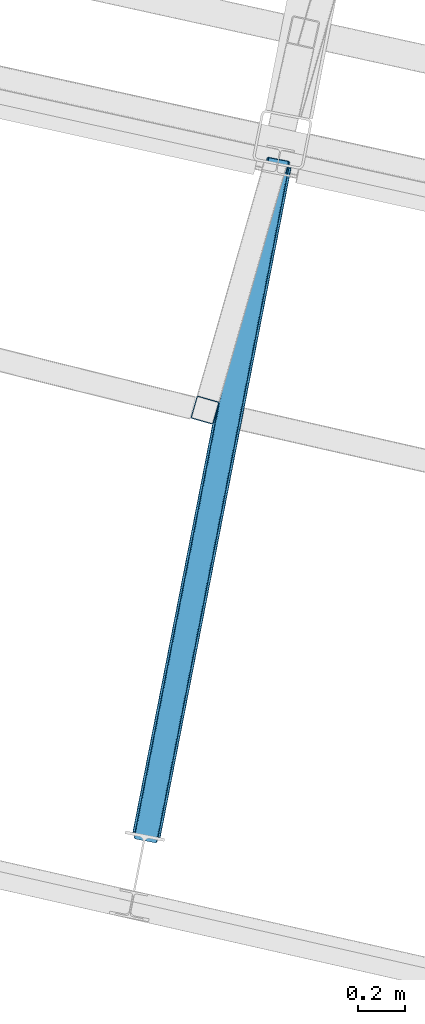
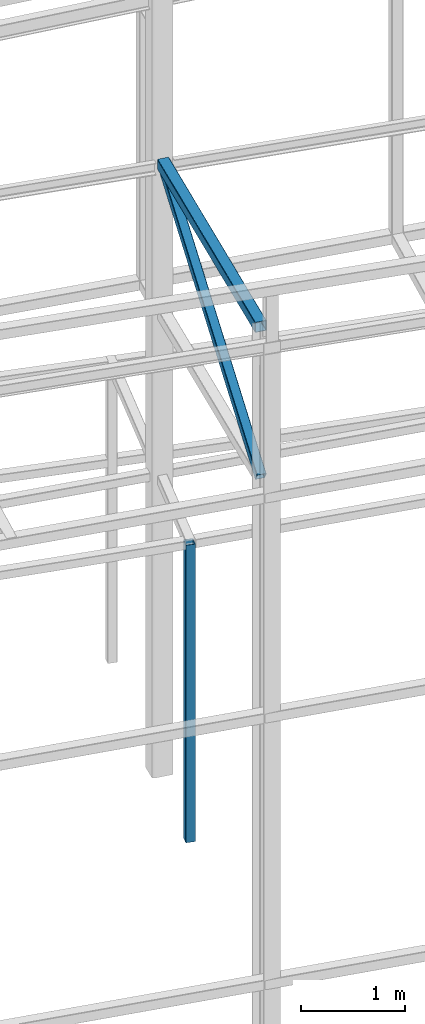
# One storey, part 15 of 215: 2 beams, 1 member, 3 elements without a shape of their own.
"""IFC2X3 building model written with IfcOpenShell, lengths in millimetres."""

import ifcopenshell
import ifcopenshell.guid

model = None  # the IFC model being written
_history = None  # IfcOwnerHistory: only IFC2X3 demands one
_inside = {}  # id of a spatial element -> (the spatial element, [elements in it])
_under = {}  # id of a project, library or spatial element -> (it, [spatial elements below it])
_declared = {}  # id of a project -> (the project, [libraries it declares])
_typed = {}  # id of a type object -> (the type object, [elements of that type])
_made_of = {}  # id of a material, layer set ... -> (it, [elements and type objects made of it])


def new_model(schema):
    """Start an empty IFC model of exactly this schema.

    Asked for "IFC4X3", IfcOpenShell would pick the latest addendum, in which some entities
    have other attributes; the version numbers below select the first issue.
    IFC2X3 requires an IfcOwnerHistory on every rooted entity: one is made here for all.
    """
    global model, _history
    if schema == "IFC4X3":
        model = ifcopenshell.file(schema_version=(4, 3, 0, 0))
    else:
        model = ifcopenshell.file(schema=schema)
    _inside.clear()
    _under.clear()
    _declared.clear()
    _typed.clear()
    _made_of.clear()
    _history = None
    if model.schema == "IFC2X3":
        org = make("IfcOrganization", Name="unknown")
        user = make(
            "IfcPersonAndOrganization",
            ThePerson=make("IfcPerson", FamilyName="unknown"),
            TheOrganization=org,
        )
        app = make(
            "IfcApplication",
            ApplicationDeveloper=org,
            Version="unknown",
            ApplicationFullName="unknown",
            ApplicationIdentifier="unknown",
        )
        _history = make(
            "IfcOwnerHistory",
            OwningUser=user,
            OwningApplication=app,
            ChangeAction="ADDED",
            CreationDate=0,
        )
    return model


def make(cls, **values):
    """One entity of the class cls with the attributes given. An attribute that is None is left unset."""
    return model.create_entity(
        cls, **{name: value for name, value in values.items() if value is not None}
    )


def rooted(cls, **values):
    """An entity with a GlobalId (a new one), such as an element, a storey or a relation."""
    return make(cls, GlobalId=ifcopenshell.guid.new(), OwnerHistory=_history, **values)


def si_unit(unit_type, name, prefix=None):
    """IfcSIUnit, for example si_unit("LENGTHUNIT", "METRE", prefix="MILLI")."""
    return make("IfcSIUnit", UnitType=unit_type, Prefix=prefix, Name=name)


def assignment(units):
    """IfcUnitAssignment: the units of a project."""
    return None if units is None else make("IfcUnitAssignment", Units=units)


def point(xyz):
    """IfcCartesianPoint."""
    return None if xyz is None else make("IfcCartesianPoint", Coordinates=xyz)


def direction(xyz):
    """IfcDirection."""
    return None if xyz is None else make("IfcDirection", DirectionRatios=xyz)


def frame(location, z_axis=None, x_axis=None):
    """IfcAxis2Placement3D, a coordinate frame: its origin and axes. An axis left out is left unset."""
    return make(
        "IfcAxis2Placement3D",
        Location=point(location),
        Axis=direction(z_axis),
        RefDirection=direction(x_axis),
    )


def frame_2d(location, x_axis=None):
    """IfcAxis2Placement2D, a coordinate frame in the plane: its origin and x axis."""
    return make(
        "IfcAxis2Placement2D", Location=point(location), RefDirection=direction(x_axis)
    )


def origin_with_axes():
    """The frame at (0, 0, 0) with the z axis (0, 0, 1) and the x axis (1, 0, 0) written out."""
    return frame((0.0, 0.0, 0.0), z_axis=(0.0, 0.0, 1.0), x_axis=(1.0, 0.0, 0.0))


def origin_2d_with_axis():
    """The frame at (0, 0) in the plane with the x axis (1, 0) written out."""
    return frame_2d((0.0, 0.0), x_axis=(1.0, 0.0))


def place(relative_to, where):
    """IfcLocalPlacement: puts the frame where relative to a parent placement (None: the world)."""
    return make(
        "IfcLocalPlacement", PlacementRelTo=relative_to, RelativePlacement=where
    )


def context(
    kind, dimensions, precision=None, world=None, true_north=None, identifier=None
):
    """IfcGeometricRepresentationContext, for example the 3D "Model" context."""
    return make(
        "IfcGeometricRepresentationContext",
        ContextIdentifier=identifier,
        ContextType=kind,
        CoordinateSpaceDimension=dimensions,
        Precision=precision,
        WorldCoordinateSystem=world,
        TrueNorth=true_north,
    )


def subcontext(parent, identifier, kind, view, scale=None):
    """IfcGeometricRepresentationSubContext, for example "Body" below "Model"."""
    return make(
        "IfcGeometricRepresentationSubContext",
        ContextIdentifier=identifier,
        ContextType=kind,
        ParentContext=parent,
        TargetScale=scale,
        TargetView=view,
    )


def project(units=None, contexts=None):
    """IfcProject with its units and contexts."""
    return rooted(
        "IfcProject",
        Name="project",
        RepresentationContexts=contexts,
        UnitsInContext=assignment(units),
    )


def spatial(cls, under=None, at=None, **own):
    """A site, building, storey or space (cls), placed at a placement, below another one or the project."""
    s = rooted(cls, ObjectPlacement=at, **own)
    if under is not None:
        _under.setdefault(under.id(), (under, []))[1].append(s)
    return s


def profile(cls, at=None, kind="AREA", **sizes):
    """A parametric profile (cls). Its sizes go by their IFC names, for example OverallWidth=200.0."""
    return make(cls, ProfileType=kind, Position=at, **sizes)


def hollow_rectangle(**sizes):
    """IfcRectangleHollowProfileDef."""
    return profile("IfcRectangleHollowProfileDef", **sizes)


def extrude(swept, where, along, depth):
    """IfcExtrudedAreaSolid: the profile swept, set in the frame where, extruded along a direction by depth."""
    return make(
        "IfcExtrudedAreaSolid",
        SweptArea=swept,
        Position=where,
        ExtrudedDirection=direction(along),
        Depth=depth,
    )


def shape(context_of_items, identifier, shape_type, items):
    """IfcShapeRepresentation: the items that make up one representation, for example the "Body"."""
    return make(
        "IfcShapeRepresentation",
        ContextOfItems=context_of_items,
        RepresentationIdentifier=identifier,
        RepresentationType=shape_type,
        Items=items,
    )


def material(Name=None, Category=None):
    """IfcMaterial."""
    return make("IfcMaterial", Name=Name, Category=Category)


def made_of(thing, what):
    """Note that an element or type object is made of a material, layer set ...; save() writes the relation."""
    if what is not None:
        _made_of.setdefault(what.id(), (what, []))[1].append(thing)
    return thing


def type_object(cls, material=None, **own):
    """A type object (cls), such as IfcWallType, which elements share."""
    return made_of(rooted(cls, **own), material)


def element(
    cls,
    number,
    at=None,
    inside=None,
    cuts=None,
    type_object=None,
    material=None,
    context=None,
    identifier="Body",
    shape_type=None,
    held_by="IfcProductDefinitionShape",
    body=None,
    shapes=None,
    **own,
):
    """One element of the class cls, such as IfcWall. Its Tag is "e" and its number.

    at: its placement. inside: the storey or other place that contains it. cuts: it is an
    opening in that element (IfcRelVoidsElement). A single representation is given by context,
    identifier, shape_type and body (its items); several are given by shapes. held_by: the class
    of the entity that holds the representations. save() writes the other relations.
    """
    e = rooted(cls, Tag="e%d" % number, ObjectPlacement=at, **own)
    if body is not None:
        shapes = [shape(context, identifier, shape_type, body)]
    if shapes is not None:
        e.Representation = make(held_by, Representations=shapes)
    if inside is not None:
        _inside.setdefault(inside.id(), (inside, []))[1].append(e)
    if cuts is not None:
        rooted(
            "IfcRelVoidsElement", RelatingBuildingElement=cuts, RelatedOpeningElement=e
        )
    if type_object is not None:
        _typed.setdefault(type_object.id(), (type_object, []))[1].append(e)
    return made_of(e, material)


def aggregate(whole, parts):
    """IfcRelAggregates: a whole, such as a stair, and the parts it consists of."""
    return rooted("IfcRelAggregates", RelatingObject=whole, RelatedObjects=parts)


def save(model, path):
    """Write the relations noted so far, then the file.

    IfcRelAggregates (storeys below a building ...), IfcRelContainedInSpatialStructure (elements
    in a storey), IfcRelDefinesByType, IfcRelAssociatesMaterial and IfcRelDeclares: one each for
    every whole, place, type object, material and project.
    """
    for whole, parts in _under.values():
        aggregate(whole, parts)
    for where, things in _inside.values():
        rooted(
            "IfcRelContainedInSpatialStructure",
            RelatedElements=things,
            RelatingStructure=where,
        )
    for kind, things in _typed.values():
        rooted("IfcRelDefinesByType", RelatedObjects=things, RelatingType=kind)
    for what, things in _made_of.values():
        rooted("IfcRelAssociatesMaterial", RelatedObjects=things, RelatingMaterial=what)
    for by, libraries in _declared.values():
        rooted("IfcRelDeclares", RelatingContext=by, RelatedDefinitions=libraries)
    model.write(path)


model = new_model("IFC2X3")

# Units and contexts
model_context = context("Model", 3, precision=1e-05, world=origin_with_axes())
body_context = subcontext(model_context, "Body", "Model", "MODEL_VIEW")
ifc_project = project(units=[si_unit("LENGTHUNIT", "METRE", prefix="MILLI"), si_unit("AREAUNIT", "SQUARE_METRE"), si_unit("VOLUMEUNIT", "CUBIC_METRE"), si_unit("MASSUNIT", "GRAM", prefix="KILO"), si_unit("TIMEUNIT", "SECOND"), si_unit("PLANEANGLEUNIT", "RADIAN"), si_unit("SOLIDANGLEUNIT", "STERADIAN"), si_unit("THERMODYNAMICTEMPERATUREUNIT", "DEGREE_CELSIUS"), si_unit("LUMINOUSINTENSITYUNIT", "LUMEN")], contexts=[model_context])

# Site, building, storey
site_placement = place(None, origin_with_axes())
site = spatial("IfcSite", under=ifc_project, at=site_placement, CompositionType="ELEMENT")
building_placement = place(site_placement, origin_with_axes())
building = spatial("IfcBuilding", under=site, at=building_placement, Name="Undefined", CompositionType="ELEMENT")
storey_placement = place(building_placement, origin_with_axes())
storey = spatial("IfcBuildingStorey", under=building, at=storey_placement, Name="Undefined", CompositionType="ELEMENT", Elevation=0.0)

# Assembly, beam
assembly_1_placement = place(storey_placement, origin_with_axes())
assembly_1 = element("IfcElementAssembly", 1, at=assembly_1_placement, inside=storey, Name="Steel Assembly", AssemblyPlace="NOTDEFINED", PredefinedType="RIGID_FRAME")
ifc_material = material(Name="STEEL/S275JR")
beam_type_1 = type_object("IfcBeamType", PredefinedType="NOTDEFINED")
beam_1_placement = place(assembly_1_placement, frame((49688.8185609857, 7951.61665949275, 6760.00000147429), z_axis=(-0.961377854576722, 0.27523193987882, 0.0), x_axis=(0.0, 0.0, -1.0)))
beam_1 = element("IfcBeam", 2, at=beam_1_placement, type_object=beam_type_1, material=ifc_material, Name="MONTANT", context=body_context, shape_type="SweptSolid", body=[
    extrude(hollow_rectangle(XDim=100.0, YDim=100.0, WallThickness=4.0, InnerFilletRadius=4.0, OuterFilletRadius=8.0, at=origin_2d_with_axis()), frame((3499.99999998675, 0.0, 0.0), z_axis=(-1.0, 0.0, 0.0), x_axis=(-6.93889390390723e-18, -1.0, -3.46944695195361e-18)), (0.0, 0.0, 1.0), 3500.0),
])
aggregate(assembly_1, [beam_1])

assembly_2_placement = place(storey_placement, origin_with_axes())
assembly_2 = element("IfcElementAssembly", 3, at=assembly_2_placement, inside=storey, Name="Steel Assembly", AssemblyPlace="NOTDEFINED", PredefinedType="RIGID_FRAME")
beam_type_2 = type_object("IfcBeamType", PredefinedType="NOTDEFINED")
beam_2_placement = place(assembly_2_placement, frame((49440.3070140235, 6146.73511545517, 10474.2845194533), z_axis=(-0.981422412140383, 0.191859451027444, 0.0), x_axis=(0.191859470081235, 0.981422408415534, 0.0)))
beam_2 = element("IfcBeam", 4, at=beam_2_placement, type_object=beam_type_2, material=ifc_material, context=body_context, shape_type="SweptSolid", body=[
    extrude(hollow_rectangle(XDim=120.0, YDim=120.0, WallThickness=5.0, InnerFilletRadius=5.0, OuterFilletRadius=10.0, at=origin_2d_with_axis()), frame((2899.79442997003, 7.27651396735187e-12, -1.81898940354586e-12), z_axis=(-1.0, 0.0, 0.0), x_axis=(-6.93889390390723e-18, -1.0, -3.46944695195361e-18)), (0.0, 0.0, 1.0), 2899.8),
])
aggregate(assembly_2, [beam_2])

# Assembly, member
assembly_3_placement = place(storey_placement, origin_with_axes())
assembly_3 = element("IfcElementAssembly", 5, at=assembly_3_placement, inside=storey, Name="Steel Assembly", AssemblyPlace="NOTDEFINED", PredefinedType="RIGID_FRAME")
member_type = type_object("IfcMemberType", PredefinedType="NOTDEFINED")
member_placement = place(assembly_3_placement, frame((49996.6599861552, 8992.65836026882, 10474.2845159194), z_axis=(-0.98134794019518, 0.192238956038234, -0.000635654000126129), x_axis=(-0.16390634095261, -0.838433320757586, -0.51977329484972)))
member = element("IfcMember", 6, at=member_placement, type_object=member_type, material=ifc_material, context=body_context, shape_type="SweptSolid", body=[
    extrude(hollow_rectangle(XDim=100.0, YDim=100.0, WallThickness=5.0, InnerFilletRadius=5.0, OuterFilletRadius=10.0, at=origin_2d_with_axis()), frame((3394.33461869513, 7.95807864051312e-13, -6.34825006933773e-14), z_axis=(-1.0, 0.0, 0.0), x_axis=(-6.93889390390723e-18, -1.0, -3.46944695195361e-18)), (0.0, 0.0, 1.0), 3394.3),
])
aggregate(assembly_3, [member])

save(model, "model.ifc")
